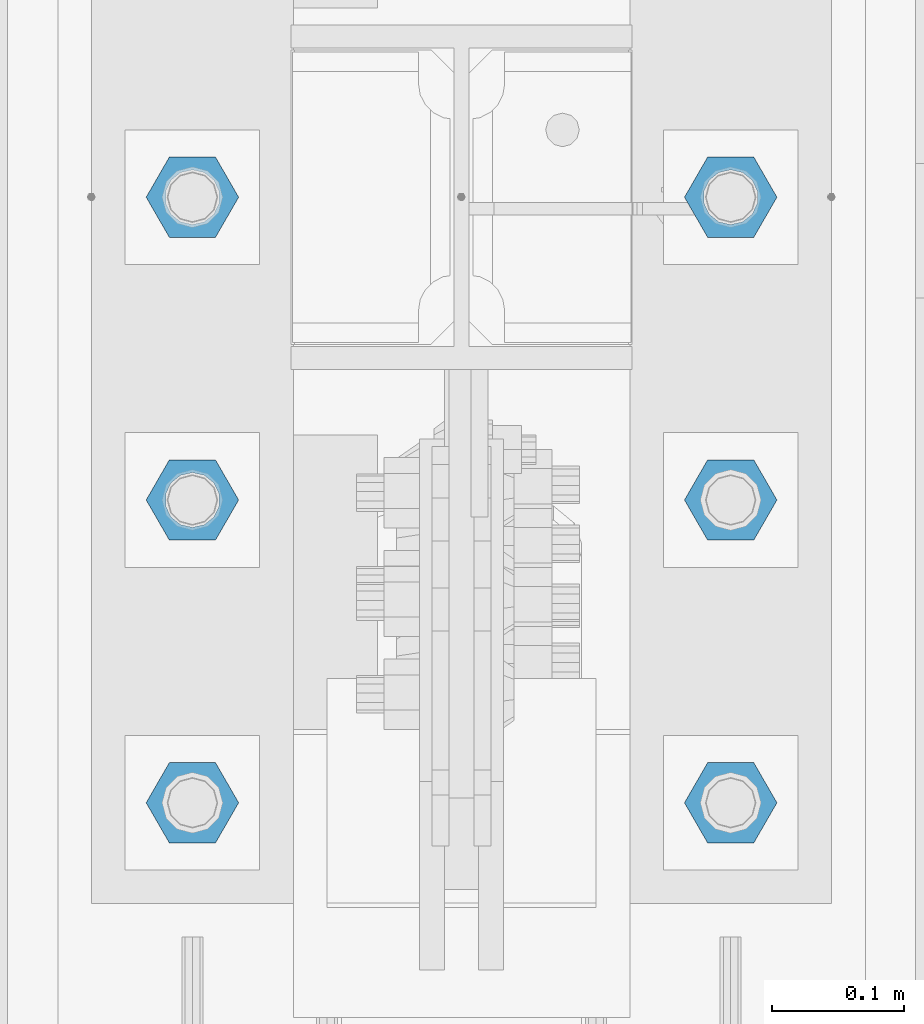
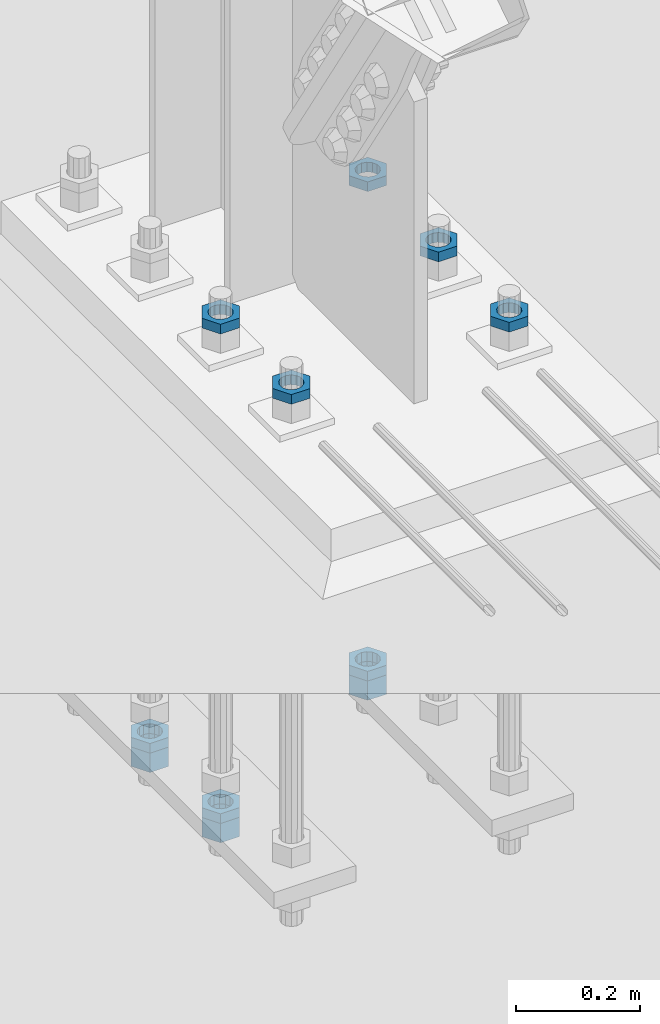
# One storey, part 2857 of 3843: 11 beams, 1 element without a shape of its own.
"""IFC2X3 building model written with IfcOpenShell, lengths in millimetres."""

from ifc_helpers import new_model, si_unit, frame, origin_with_axes, place, context, subcontext, project, spatial, faceted_brep, material, type_object, element, aggregate, save


model = new_model("IFC2X3")

# Units and contexts
model_context = context("Model", 3, precision=1e-05, world=origin_with_axes())
body_context = subcontext(model_context, "Body", "Model", "MODEL_VIEW")
ifc_project = project(units=[si_unit("LENGTHUNIT", "METRE", prefix="MILLI"), si_unit("AREAUNIT", "SQUARE_METRE"), si_unit("VOLUMEUNIT", "CUBIC_METRE"), si_unit("MASSUNIT", "GRAM", prefix="KILO"), si_unit("TIMEUNIT", "SECOND"), si_unit("PLANEANGLEUNIT", "RADIAN"), si_unit("SOLIDANGLEUNIT", "STERADIAN"), si_unit("THERMODYNAMICTEMPERATUREUNIT", "DEGREE_CELSIUS"), si_unit("LUMINOUSINTENSITYUNIT", "LUMEN")], contexts=[model_context])

# Site, building, storey
site_placement = place(None, origin_with_axes())
site = spatial("IfcSite", under=ifc_project, at=site_placement, CompositionType="ELEMENT")
building_placement = place(site_placement, origin_with_axes())
building = spatial("IfcBuilding", under=site, at=building_placement, Name="Undefined", CompositionType="ELEMENT")
storey_placement = place(building_placement, origin_with_axes())
storey = spatial("IfcBuildingStorey", under=building, at=storey_placement, Name="Undefined", CompositionType="ELEMENT", Elevation=0.0)

# Assembly, beams
assembly_placement = place(storey_placement, origin_with_axes())
assembly = element("IfcElementAssembly", 1, at=assembly_placement, inside=storey, Name="TEMPLATE", AssemblyPlace="NOTDEFINED", PredefinedType="RIGID_FRAME")
ifc_material = material(Name="STEEL/A572-50")
beam_type_1 = type_object("IfcBeamType", Name="1-1/2_HEAVY_HEX_NUT", PredefinedType="NOTDEFINED")
beam_1_placement = place(assembly_placement, frame((-203.2, 104559.100004884, 28905.2), z_axis=(0.0, -1.0, 0.0), x_axis=(0.0, 0.0, -1.0)))
beam_1 = element("IfcBeam", 2, at=beam_1_placement, type_object=beam_type_1, material=ifc_material, Name="NUT", ObjectType="1-1/2_HEAVY_HEX_NUT", context=body_context, shape_type="Brep", body=[
    faceted_brep([(0.0, -34.9199981689453, 0.0), (0.0, -17.4599990844727, -30.25), (38.0999999999985, -17.4599990844727, -30.25), (38.0999999999985, -34.9199981689453, 0.0), (0.0, 17.4599990844727, -30.25), (38.0999999999985, 17.4599990844727, -30.25), (0.0, 34.9199981689453, 0.0), (38.0999999999985, 34.9199981689453, 0.0), (0.0, 17.4599990844727, 30.25), (38.0999999999985, 17.4599990844727, 30.25), (0.0, -17.4599990844727, 30.25), (38.0999999999985, -17.4599990844727, 30.25), (0.0, 0.0, 20.6399993896484), (0.0, 8.9553601105581, 18.5959968835959), (38.0999999999985, 8.9553601105581, 18.5959968835959), (38.0999999999985, 0.0, 20.6399993896484), (0.0, 16.1370013209525, 12.8688291298167), (38.0999999999985, 16.1370013209525, 12.8688291298167), (0.0, 20.1225115123816, 4.59283194104501), (38.0999999999985, 20.1225115123816, 4.59283194104501), (0.0, 20.1225115123816, -4.59283194104501), (38.0999999999985, 20.1225115123816, -4.59283194104501), (0.0, 16.1370013209525, -12.8688291298167), (38.0999999999985, 16.1370013209525, -12.8688291298167), (0.0, 8.9553601105581, -18.5959968835959), (38.0999999999985, 8.9553601105581, -18.5959968835959), (0.0, 0.0, -20.6399993896484), (38.0999999999985, 0.0, -20.6399993896484), (0.0, -8.9553601105581, -18.5959968835959), (38.0999999999985, -8.9553601105581, -18.5959968835959), (0.0, -16.1370013209525, -12.8688291298167), (38.0999999999985, -16.1370013209525, -12.8688291298167), (0.0, -20.1225115123816, -4.59283194104501), (38.0999999999985, -20.1225115123816, -4.59283194104501), (0.0, -20.1225115123816, 4.59283194104501), (38.0999999999985, -20.1225115123816, 4.59283194104501), (0.0, -16.1370013209525, 12.8688291298167), (38.0999999999985, -16.1370013209525, 12.8688291298167), (0.0, -8.9553601105581, 18.5959968835959), (38.0999999999985, -8.9553601105581, 18.5959968835959)], [[[0, 1, 2, 3]], [[1, 4, 5, 2]], [[4, 6, 7, 5]], [[6, 8, 9, 7]], [[8, 10, 11, 9]], [[10, 0, 3, 11]], [[12, 13, 14, 15]], [[13, 16, 17, 14]], [[16, 18, 19, 17]], [[18, 20, 21, 19]], [[20, 22, 23, 21]], [[22, 24, 25, 23]], [[24, 26, 27, 25]], [[26, 28, 29, 27]], [[28, 30, 31, 29]], [[30, 32, 33, 31]], [[32, 34, 35, 33]], [[34, 36, 37, 35]], [[36, 38, 39, 37]], [[38, 12, 15, 39]], [[5, 7, 9, 11, 3, 2], [17, 19, 21, 23, 25, 27, 29, 31, 33, 35, 37, 39, 15, 14]], [[10, 8, 6, 4, 1, 0], [38, 36, 34, 32, 30, 28, 26, 24, 22, 20, 18, 16, 13, 12]]]),
])
beam_2_placement = place(assembly_placement, frame((-203.2, 104330.500004884, 28905.2), z_axis=(0.0, -1.0, 0.0), x_axis=(0.0, 0.0, -1.0)))
beam_2 = element("IfcBeam", 3, at=beam_2_placement, type_object=beam_type_1, material=ifc_material, Name="NUT", ObjectType="1-1/2_HEAVY_HEX_NUT", context=body_context, shape_type="Brep", body=[
    faceted_brep([(0.0, -34.9199981689453, 0.0), (0.0, -17.4599990844727, -30.25), (38.0999999999985, -17.4599990844727, -30.25), (38.0999999999985, -34.9199981689453, 0.0), (0.0, 17.4599990844727, -30.25), (38.0999999999985, 17.4599990844727, -30.25), (0.0, 34.9199981689453, 0.0), (38.0999999999985, 34.9199981689453, 0.0), (0.0, 17.4599990844727, 30.25), (38.0999999999985, 17.4599990844727, 30.25), (0.0, -17.4599990844727, 30.25), (38.0999999999985, -17.4599990844727, 30.25), (0.0, 0.0, 20.6399993896484), (0.0, 8.9553601105581, 18.5959968835959), (38.0999999999985, 8.9553601105581, 18.5959968835959), (38.0999999999985, 0.0, 20.6399993896484), (0.0, 16.1370013209525, 12.8688291298167), (38.0999999999985, 16.1370013209525, 12.8688291298167), (0.0, 20.1225115123816, 4.59283194104501), (38.0999999999985, 20.1225115123816, 4.59283194104501), (0.0, 20.1225115123816, -4.59283194104501), (38.0999999999985, 20.1225115123816, -4.59283194104501), (0.0, 16.1370013209525, -12.8688291298167), (38.0999999999985, 16.1370013209525, -12.8688291298167), (0.0, 8.9553601105581, -18.5959968835959), (38.0999999999985, 8.9553601105581, -18.5959968835959), (0.0, 0.0, -20.6399993896484), (38.0999999999985, 0.0, -20.6399993896484), (0.0, -8.9553601105581, -18.5959968835959), (38.0999999999985, -8.9553601105581, -18.5959968835959), (0.0, -16.1370013209525, -12.8688291298167), (38.0999999999985, -16.1370013209525, -12.8688291298167), (0.0, -20.1225115123816, -4.59283194104501), (38.0999999999985, -20.1225115123816, -4.59283194104501), (0.0, -20.1225115123816, 4.59283194104501), (38.0999999999985, -20.1225115123816, 4.59283194104501), (0.0, -16.1370013209525, 12.8688291298167), (38.0999999999985, -16.1370013209525, 12.8688291298167), (0.0, -8.9553601105581, 18.5959968835959), (38.0999999999985, -8.9553601105581, 18.5959968835959)], [[[0, 1, 2, 3]], [[1, 4, 5, 2]], [[4, 6, 7, 5]], [[6, 8, 9, 7]], [[8, 10, 11, 9]], [[10, 0, 3, 11]], [[12, 13, 14, 15]], [[13, 16, 17, 14]], [[16, 18, 19, 17]], [[18, 20, 21, 19]], [[20, 22, 23, 21]], [[22, 24, 25, 23]], [[24, 26, 27, 25]], [[26, 28, 29, 27]], [[28, 30, 31, 29]], [[30, 32, 33, 31]], [[32, 34, 35, 33]], [[34, 36, 37, 35]], [[36, 38, 39, 37]], [[38, 12, 15, 39]], [[5, 7, 9, 11, 3, 2], [17, 19, 21, 23, 25, 27, 29, 31, 33, 35, 37, 39, 15, 14]], [[10, 8, 6, 4, 1, 0], [38, 36, 34, 32, 30, 28, 26, 24, 22, 20, 18, 16, 13, 12]]]),
])
beam_3_placement = place(assembly_placement, frame((203.2, 104559.100019533, 28905.2), z_axis=(0.0, 1.0, 0.0), x_axis=(0.0, 0.0, -1.0)))
beam_3 = element("IfcBeam", 4, at=beam_3_placement, type_object=beam_type_1, material=ifc_material, Name="NUT", ObjectType="1-1/2_HEAVY_HEX_NUT", context=body_context, shape_type="Brep", body=[
    faceted_brep([(0.0, -34.9199981689453, 0.0), (0.0, -17.4599990844727, -30.25), (38.0999999999985, -17.4599990844727, -30.25), (38.0999999999985, -34.9199981689453, 0.0), (0.0, 17.4599990844727, -30.25), (38.0999999999985, 17.4599990844727, -30.25), (0.0, 34.9199981689453, 0.0), (38.0999999999985, 34.9199981689453, 0.0), (0.0, 17.4599990844727, 30.25), (38.0999999999985, 17.4599990844727, 30.25), (0.0, -17.4599990844727, 30.25), (38.0999999999985, -17.4599990844727, 30.25), (0.0, 0.0, 20.6399993896484), (0.0, 8.9553601105581, 18.5959968835959), (38.0999999999985, 8.9553601105581, 18.5959968835959), (38.0999999999985, 0.0, 20.6399993896484), (0.0, 16.1370013209525, 12.8688291298167), (38.0999999999985, 16.1370013209525, 12.8688291298167), (0.0, 20.1225115123816, 4.59283194104501), (38.0999999999985, 20.1225115123816, 4.59283194104501), (0.0, 20.1225115123816, -4.59283194104501), (38.0999999999985, 20.1225115123816, -4.59283194104501), (0.0, 16.1370013209525, -12.8688291298167), (38.0999999999985, 16.1370013209525, -12.8688291298167), (0.0, 8.9553601105581, -18.5959968835959), (38.0999999999985, 8.9553601105581, -18.5959968835959), (0.0, 0.0, -20.6399993896484), (38.0999999999985, 0.0, -20.6399993896484), (0.0, -8.9553601105581, -18.5959968835959), (38.0999999999985, -8.9553601105581, -18.5959968835959), (0.0, -16.1370013209525, -12.8688291298167), (38.0999999999985, -16.1370013209525, -12.8688291298167), (0.0, -20.1225115123816, -4.59283194104501), (38.0999999999985, -20.1225115123816, -4.59283194104501), (0.0, -20.1225115123816, 4.59283194104501), (38.0999999999985, -20.1225115123816, 4.59283194104501), (0.0, -16.1370013209525, 12.8688291298167), (38.0999999999985, -16.1370013209525, 12.8688291298167), (0.0, -8.9553601105581, 18.5959968835959), (38.0999999999985, -8.9553601105581, 18.5959968835959)], [[[0, 1, 2, 3]], [[1, 4, 5, 2]], [[4, 6, 7, 5]], [[6, 8, 9, 7]], [[8, 10, 11, 9]], [[10, 0, 3, 11]], [[12, 13, 14, 15]], [[13, 16, 17, 14]], [[16, 18, 19, 17]], [[18, 20, 21, 19]], [[20, 22, 23, 21]], [[22, 24, 25, 23]], [[24, 26, 27, 25]], [[26, 28, 29, 27]], [[28, 30, 31, 29]], [[30, 32, 33, 31]], [[32, 34, 35, 33]], [[34, 36, 37, 35]], [[36, 38, 39, 37]], [[38, 12, 15, 39]], [[5, 7, 9, 11, 3, 2], [17, 19, 21, 23, 25, 27, 29, 31, 33, 35, 37, 39, 15, 14]], [[10, 8, 6, 4, 1, 0], [38, 36, 34, 32, 30, 28, 26, 24, 22, 20, 18, 16, 13, 12]]]),
])
beam_type_2 = type_object("IfcBeamType", Name="1-1/2_HALF_NUT", PredefinedType="NOTDEFINED")
beam_4_placement = place(assembly_placement, frame((-203.2, 104330.500000001, 29889.45), z_axis=(0.0, -1.0, 0.0), x_axis=(0.0, 0.0, -1.0)))
beam_4 = element("IfcBeam", 5, at=beam_4_placement, type_object=beam_type_2, material=ifc_material, Name="NUT", ObjectType="1-1/2_HALF_NUT", context=body_context, shape_type="Brep", body=[
    faceted_brep([(0.0, -34.9199981689453, 0.0), (0.0, -17.4599990844727, -30.25), (19.0500000000029, -17.4599990844727, -30.25), (19.0500000000029, -34.9199981689453, 0.0), (0.0, 17.4599990844727, -30.25), (19.0500000000029, 17.4599990844727, -30.25), (0.0, 34.9199981689453, 0.0), (19.0500000000029, 34.9199981689453, 0.0), (0.0, 17.4599990844727, 30.25), (19.0500000000029, 17.4599990844727, 30.25), (0.0, -17.4599990844727, 30.25), (19.0500000000029, -17.4599990844727, 30.25), (0.0, 0.0, 20.6399993896484), (0.0, 8.9553601105581, 18.5959968835959), (19.0500000000029, 8.95536011056538, 18.5959968835959), (19.0500000000029, 0.0, 20.6399993896484), (0.0, 16.1370013209525, 12.8688291298167), (19.0500000000029, 16.1370013209489, 12.8688291298167), (0.0, 20.1225115123816, 4.59283194104501), (19.0500000000029, 20.1225115123852, 4.59283194104501), (0.0, 20.1225115123816, -4.59283194104501), (19.0500000000029, 20.1225115123852, -4.59283194104501), (0.0, 16.1370013209525, -12.8688291298167), (19.0500000000029, 16.1370013209489, -12.8688291298167), (0.0, 8.9553601105581, -18.5959968835959), (19.0500000000029, 8.95536011056538, -18.5959968835959), (0.0, 0.0, -20.6399993896484), (19.0500000000029, 0.0, -20.6399993896484), (0.0, -8.9553601105581, -18.5959968835959), (19.0500000000029, -8.95536011056538, -18.5959968835959), (0.0, -16.1370013209525, -12.8688291298167), (19.0500000000029, -16.1370013209489, -12.8688291298167), (0.0, -20.1225115123816, -4.59283194104501), (19.0500000000029, -20.1225115123852, -4.59283194104501), (0.0, -20.1225115123816, 4.59283194104501), (19.0500000000029, -20.1225115123852, 4.59283194104501), (0.0, -16.1370013209525, 12.8688291298167), (19.0500000000029, -16.1370013209489, 12.8688291298167), (0.0, -8.9553601105581, 18.5959968835959), (19.0500000000029, -8.95536011056538, 18.5959968835959)], [[[0, 1, 2, 3]], [[1, 4, 5, 2]], [[4, 6, 7, 5]], [[6, 8, 9, 7]], [[8, 10, 11, 9]], [[10, 0, 3, 11]], [[12, 13, 14, 15]], [[13, 16, 17, 14]], [[16, 18, 19, 17]], [[18, 20, 21, 19]], [[20, 22, 23, 21]], [[22, 24, 25, 23]], [[24, 26, 27, 25]], [[26, 28, 29, 27]], [[28, 30, 31, 29]], [[30, 32, 33, 31]], [[32, 34, 35, 33]], [[34, 36, 37, 35]], [[36, 38, 39, 37]], [[38, 12, 15, 39]], [[5, 7, 9, 11, 3, 2], [17, 19, 21, 23, 25, 27, 29, 31, 33, 35, 37, 39, 15, 14]], [[10, 8, 6, 4, 1, 0], [38, 36, 34, 32, 30, 28, 26, 24, 22, 20, 18, 16, 13, 12]]]),
])
beam_5_placement = place(assembly_placement, frame((203.2, 104559.100024415, 29889.45), z_axis=(0.0, 1.0, 0.0), x_axis=(0.0, 0.0, -1.0)))
beam_5 = element("IfcBeam", 6, at=beam_5_placement, type_object=beam_type_2, material=ifc_material, Name="NUT", ObjectType="1-1/2_HALF_NUT", context=body_context, shape_type="Brep", body=[
    faceted_brep([(0.0, -34.9199981689453, 0.0), (0.0, -17.4599990844727, -30.25), (19.0500000000029, -17.4599990844727, -30.25), (19.0500000000029, -34.9199981689453, 0.0), (0.0, 17.4599990844727, -30.25), (19.0500000000029, 17.4599990844727, -30.25), (0.0, 34.9199981689453, 0.0), (19.0500000000029, 34.9199981689453, 0.0), (0.0, 17.4599990844727, 30.25), (19.0500000000029, 17.4599990844727, 30.25), (0.0, -17.4599990844727, 30.25), (19.0500000000029, -17.4599990844727, 30.25), (0.0, 0.0, 20.6399993896484), (0.0, 8.9553601105581, 18.5959968835959), (19.0500000000029, 8.95536011056538, 18.5959968835959), (19.0500000000029, 0.0, 20.6399993896484), (0.0, 16.1370013209525, 12.8688291298167), (19.0500000000029, 16.1370013209489, 12.8688291298167), (0.0, 20.1225115123816, 4.59283194104501), (19.0500000000029, 20.1225115123852, 4.59283194104501), (0.0, 20.1225115123816, -4.59283194104501), (19.0500000000029, 20.1225115123852, -4.59283194104501), (0.0, 16.1370013209525, -12.8688291298167), (19.0500000000029, 16.1370013209489, -12.8688291298167), (0.0, 8.9553601105581, -18.5959968835959), (19.0500000000029, 8.95536011056538, -18.5959968835959), (0.0, 0.0, -20.6399993896484), (19.0500000000029, 0.0, -20.6399993896484), (0.0, -8.9553601105581, -18.5959968835959), (19.0500000000029, -8.95536011056538, -18.5959968835959), (0.0, -16.1370013209525, -12.8688291298167), (19.0500000000029, -16.1370013209489, -12.8688291298167), (0.0, -20.1225115123816, -4.59283194104501), (19.0500000000029, -20.1225115123852, -4.59283194104501), (0.0, -20.1225115123816, 4.59283194104501), (19.0500000000029, -20.1225115123852, 4.59283194104501), (0.0, -16.1370013209525, 12.8688291298167), (19.0500000000029, -16.1370013209489, 12.8688291298167), (0.0, -8.9553601105581, 18.5959968835959), (19.0500000000029, -8.95536011056538, 18.5959968835959)], [[[0, 1, 2, 3]], [[1, 4, 5, 2]], [[4, 6, 7, 5]], [[6, 8, 9, 7]], [[8, 10, 11, 9]], [[10, 0, 3, 11]], [[12, 13, 14, 15]], [[13, 16, 17, 14]], [[16, 18, 19, 17]], [[18, 20, 21, 19]], [[20, 22, 23, 21]], [[22, 24, 25, 23]], [[24, 26, 27, 25]], [[26, 28, 29, 27]], [[28, 30, 31, 29]], [[30, 32, 33, 31]], [[32, 34, 35, 33]], [[34, 36, 37, 35]], [[36, 38, 39, 37]], [[38, 12, 15, 39]], [[5, 7, 9, 11, 3, 2], [17, 19, 21, 23, 25, 27, 29, 31, 33, 35, 37, 39, 15, 14]], [[10, 8, 6, 4, 1, 0], [38, 36, 34, 32, 30, 28, 26, 24, 22, 20, 18, 16, 13, 12]]]),
])
beam_6_placement = place(assembly_placement, frame((203.2, 104330.500024415, 29889.45), z_axis=(0.0, 1.0, 0.0), x_axis=(0.0, 0.0, -1.0)))
beam_6 = element("IfcBeam", 7, at=beam_6_placement, type_object=beam_type_2, material=ifc_material, Name="NUT", ObjectType="1-1/2_HALF_NUT", context=body_context, shape_type="Brep", body=[
    faceted_brep([(0.0, -34.9199981689453, 0.0), (0.0, -17.4599990844727, -30.25), (19.0500000000029, -17.4599990844727, -30.25), (19.0500000000029, -34.9199981689453, 0.0), (0.0, 17.4599990844727, -30.25), (19.0500000000029, 17.4599990844727, -30.25), (0.0, 34.9199981689453, 0.0), (19.0500000000029, 34.9199981689453, 0.0), (0.0, 17.4599990844727, 30.25), (19.0500000000029, 17.4599990844727, 30.25), (0.0, -17.4599990844727, 30.25), (19.0500000000029, -17.4599990844727, 30.25), (0.0, 0.0, 20.6399993896484), (0.0, 8.9553601105581, 18.5959968835959), (19.0500000000029, 8.95536011056538, 18.5959968835959), (19.0500000000029, 0.0, 20.6399993896484), (0.0, 16.1370013209525, 12.8688291298167), (19.0500000000029, 16.1370013209489, 12.8688291298167), (0.0, 20.1225115123816, 4.59283194104501), (19.0500000000029, 20.1225115123852, 4.59283194104501), (0.0, 20.1225115123816, -4.59283194104501), (19.0500000000029, 20.1225115123852, -4.59283194104501), (0.0, 16.1370013209525, -12.8688291298167), (19.0500000000029, 16.1370013209489, -12.8688291298167), (0.0, 8.9553601105581, -18.5959968835959), (19.0500000000029, 8.95536011056538, -18.5959968835959), (0.0, 0.0, -20.6399993896484), (19.0500000000029, 0.0, -20.6399993896484), (0.0, -8.9553601105581, -18.5959968835959), (19.0500000000029, -8.95536011056538, -18.5959968835959), (0.0, -16.1370013209525, -12.8688291298167), (19.0500000000029, -16.1370013209489, -12.8688291298167), (0.0, -20.1225115123816, -4.59283194104501), (19.0500000000029, -20.1225115123852, -4.59283194104501), (0.0, -20.1225115123816, 4.59283194104501), (19.0500000000029, -20.1225115123852, 4.59283194104501), (0.0, -16.1370013209525, 12.8688291298167), (19.0500000000029, -16.1370013209489, 12.8688291298167), (0.0, -8.9553601105581, 18.5959968835959), (19.0500000000029, -8.95536011056538, 18.5959968835959)], [[[0, 1, 2, 3]], [[1, 4, 5, 2]], [[4, 6, 7, 5]], [[6, 8, 9, 7]], [[8, 10, 11, 9]], [[10, 0, 3, 11]], [[12, 13, 14, 15]], [[13, 16, 17, 14]], [[16, 18, 19, 17]], [[18, 20, 21, 19]], [[20, 22, 23, 21]], [[22, 24, 25, 23]], [[24, 26, 27, 25]], [[26, 28, 29, 27]], [[28, 30, 31, 29]], [[30, 32, 33, 31]], [[32, 34, 35, 33]], [[34, 36, 37, 35]], [[36, 38, 39, 37]], [[38, 12, 15, 39]], [[5, 7, 9, 11, 3, 2], [17, 19, 21, 23, 25, 27, 29, 31, 33, 35, 37, 39, 15, 14]], [[10, 8, 6, 4, 1, 0], [38, 36, 34, 32, 30, 28, 26, 24, 22, 20, 18, 16, 13, 12]]]),
])
beam_7_placement = place(assembly_placement, frame((-203.2, 104101.900024415, 29889.45), z_axis=(0.0, 1.0, 0.0), x_axis=(0.0, 0.0, -1.0)))
beam_7 = element("IfcBeam", 8, at=beam_7_placement, type_object=beam_type_2, material=ifc_material, Name="NUT", ObjectType="1-1/2_HALF_NUT", context=body_context, shape_type="Brep", body=[
    faceted_brep([(0.0, -34.9199981689453, 0.0), (0.0, -17.4599990844727, -30.25), (19.0500000000029, -17.4599990844727, -30.25), (19.0500000000029, -34.9199981689453, 0.0), (0.0, 17.4599990844727, -30.25), (19.0500000000029, 17.4599990844727, -30.25), (0.0, 34.9199981689453, 0.0), (19.0500000000029, 34.9199981689453, 0.0), (0.0, 17.4599990844727, 30.25), (19.0500000000029, 17.4599990844727, 30.25), (0.0, -17.4599990844727, 30.25), (19.0500000000029, -17.4599990844727, 30.25), (0.0, 0.0, 20.6399993896484), (0.0, 8.9553601105581, 18.5959968835959), (19.0500000000029, 8.95536011056538, 18.5959968835959), (19.0500000000029, 0.0, 20.6399993896484), (0.0, 16.1370013209525, 12.8688291298167), (19.0500000000029, 16.1370013209489, 12.8688291298167), (0.0, 20.1225115123816, 4.59283194104501), (19.0500000000029, 20.1225115123852, 4.59283194104501), (0.0, 20.1225115123816, -4.59283194104501), (19.0500000000029, 20.1225115123852, -4.59283194104501), (0.0, 16.1370013209525, -12.8688291298167), (19.0500000000029, 16.1370013209489, -12.8688291298167), (0.0, 8.9553601105581, -18.5959968835959), (19.0500000000029, 8.95536011056538, -18.5959968835959), (0.0, 0.0, -20.6399993896484), (19.0500000000029, 0.0, -20.6399993896484), (0.0, -8.9553601105581, -18.5959968835959), (19.0500000000029, -8.95536011056538, -18.5959968835959), (0.0, -16.1370013209525, -12.8688291298167), (19.0500000000029, -16.1370013209489, -12.8688291298167), (0.0, -20.1225115123816, -4.59283194104501), (19.0500000000029, -20.1225115123852, -4.59283194104501), (0.0, -20.1225115123816, 4.59283194104501), (19.0500000000029, -20.1225115123852, 4.59283194104501), (0.0, -16.1370013209525, 12.8688291298167), (19.0500000000029, -16.1370013209489, 12.8688291298167), (0.0, -8.9553601105581, 18.5959968835959), (19.0500000000029, -8.95536011056538, 18.5959968835959)], [[[0, 1, 2, 3]], [[1, 4, 5, 2]], [[4, 6, 7, 5]], [[6, 8, 9, 7]], [[8, 10, 11, 9]], [[10, 0, 3, 11]], [[12, 13, 14, 15]], [[13, 16, 17, 14]], [[16, 18, 19, 17]], [[18, 20, 21, 19]], [[20, 22, 23, 21]], [[22, 24, 25, 23]], [[24, 26, 27, 25]], [[26, 28, 29, 27]], [[28, 30, 31, 29]], [[30, 32, 33, 31]], [[32, 34, 35, 33]], [[34, 36, 37, 35]], [[36, 38, 39, 37]], [[38, 12, 15, 39]], [[5, 7, 9, 11, 3, 2], [17, 19, 21, 23, 25, 27, 29, 31, 33, 35, 37, 39, 15, 14]], [[10, 8, 6, 4, 1, 0], [38, 36, 34, 32, 30, 28, 26, 24, 22, 20, 18, 16, 13, 12]]]),
])
beam_8_placement = place(assembly_placement, frame((203.2, 104101.900024415, 29889.45), z_axis=(0.0, 1.0, 0.0), x_axis=(0.0, 0.0, -1.0)))
beam_8 = element("IfcBeam", 9, at=beam_8_placement, type_object=beam_type_2, material=ifc_material, Name="NUT", ObjectType="1-1/2_HALF_NUT", context=body_context, shape_type="Brep", body=[
    faceted_brep([(0.0, -34.9199981689453, 0.0), (0.0, -17.4599990844727, -30.25), (19.0500000000029, -17.4599990844727, -30.25), (19.0500000000029, -34.9199981689453, 0.0), (0.0, 17.4599990844727, -30.25), (19.0500000000029, 17.4599990844727, -30.25), (0.0, 34.9199981689453, 0.0), (19.0500000000029, 34.9199981689453, 0.0), (0.0, 17.4599990844727, 30.25), (19.0500000000029, 17.4599990844727, 30.25), (0.0, -17.4599990844727, 30.25), (19.0500000000029, -17.4599990844727, 30.25), (0.0, 0.0, 20.6399993896484), (0.0, 8.9553601105581, 18.5959968835959), (19.0500000000029, 8.95536011056538, 18.5959968835959), (19.0500000000029, 0.0, 20.6399993896484), (0.0, 16.1370013209525, 12.8688291298167), (19.0500000000029, 16.1370013209489, 12.8688291298167), (0.0, 20.1225115123816, 4.59283194104501), (19.0500000000029, 20.1225115123852, 4.59283194104501), (0.0, 20.1225115123816, -4.59283194104501), (19.0500000000029, 20.1225115123852, -4.59283194104501), (0.0, 16.1370013209525, -12.8688291298167), (19.0500000000029, 16.1370013209489, -12.8688291298167), (0.0, 8.9553601105581, -18.5959968835959), (19.0500000000029, 8.95536011056538, -18.5959968835959), (0.0, 0.0, -20.6399993896484), (19.0500000000029, 0.0, -20.6399993896484), (0.0, -8.9553601105581, -18.5959968835959), (19.0500000000029, -8.95536011056538, -18.5959968835959), (0.0, -16.1370013209525, -12.8688291298167), (19.0500000000029, -16.1370013209489, -12.8688291298167), (0.0, -20.1225115123816, -4.59283194104501), (19.0500000000029, -20.1225115123852, -4.59283194104501), (0.0, -20.1225115123816, 4.59283194104501), (19.0500000000029, -20.1225115123852, 4.59283194104501), (0.0, -16.1370013209525, 12.8688291298167), (19.0500000000029, -16.1370013209489, 12.8688291298167), (0.0, -8.9553601105581, 18.5959968835959), (19.0500000000029, -8.95536011056538, 18.5959968835959)], [[[0, 1, 2, 3]], [[1, 4, 5, 2]], [[4, 6, 7, 5]], [[6, 8, 9, 7]], [[8, 10, 11, 9]], [[10, 0, 3, 11]], [[12, 13, 14, 15]], [[13, 16, 17, 14]], [[16, 18, 19, 17]], [[18, 20, 21, 19]], [[20, 22, 23, 21]], [[22, 24, 25, 23]], [[24, 26, 27, 25]], [[26, 28, 29, 27]], [[28, 30, 31, 29]], [[30, 32, 33, 31]], [[32, 34, 35, 33]], [[34, 36, 37, 35]], [[36, 38, 39, 37]], [[38, 12, 15, 39]], [[5, 7, 9, 11, 3, 2], [17, 19, 21, 23, 25, 27, 29, 31, 33, 35, 37, 39, 15, 14]], [[10, 8, 6, 4, 1, 0], [38, 36, 34, 32, 30, 28, 26, 24, 22, 20, 18, 16, 13, 12]]]),
])
beam_9_placement = place(assembly_placement, frame((-203.2, 104559.100012208, 28924.25), z_axis=(0.0, -1.0, 0.0), x_axis=(0.0, 0.0, -1.0)))
beam_9 = element("IfcBeam", 10, at=beam_9_placement, type_object=beam_type_2, material=ifc_material, Name="NUT", ObjectType="1-1/2_HALF_NUT", context=body_context, shape_type="Brep", body=[
    faceted_brep([(0.0, -34.9199981689453, 0.0), (0.0, -17.4599990844727, -30.25), (19.0500000000029, -17.4599990844727, -30.25), (19.0500000000029, -34.9199981689453, 0.0), (0.0, 17.4599990844727, -30.25), (19.0500000000029, 17.4599990844727, -30.25), (0.0, 34.9199981689453, 0.0), (19.0500000000029, 34.9199981689453, 0.0), (0.0, 17.4599990844727, 30.25), (19.0500000000029, 17.4599990844727, 30.25), (0.0, -17.4599990844727, 30.25), (19.0500000000029, -17.4599990844727, 30.25), (0.0, 0.0, 20.6399993896484), (0.0, 8.9553601105581, 18.5959968835959), (19.0500000000029, 8.95536011056538, 18.5959968835959), (19.0500000000029, 0.0, 20.6399993896484), (0.0, 16.1370013209525, 12.8688291298167), (19.0500000000029, 16.1370013209489, 12.8688291298167), (0.0, 20.1225115123816, 4.59283194104501), (19.0500000000029, 20.1225115123852, 4.59283194104501), (0.0, 20.1225115123816, -4.59283194104501), (19.0500000000029, 20.1225115123852, -4.59283194104501), (0.0, 16.1370013209525, -12.8688291298167), (19.0500000000029, 16.1370013209489, -12.8688291298167), (0.0, 8.9553601105581, -18.5959968835959), (19.0500000000029, 8.95536011056538, -18.5959968835959), (0.0, 0.0, -20.6399993896484), (19.0500000000029, 0.0, -20.6399993896484), (0.0, -8.9553601105581, -18.5959968835959), (19.0500000000029, -8.95536011056538, -18.5959968835959), (0.0, -16.1370013209525, -12.8688291298167), (19.0500000000029, -16.1370013209489, -12.8688291298167), (0.0, -20.1225115123816, -4.59283194104501), (19.0500000000029, -20.1225115123852, -4.59283194104501), (0.0, -20.1225115123816, 4.59283194104501), (19.0500000000029, -20.1225115123852, 4.59283194104501), (0.0, -16.1370013209525, 12.8688291298167), (19.0500000000029, -16.1370013209489, 12.8688291298167), (0.0, -8.9553601105581, 18.5959968835959), (19.0500000000029, -8.95536011056538, 18.5959968835959)], [[[0, 1, 2, 3]], [[1, 4, 5, 2]], [[4, 6, 7, 5]], [[6, 8, 9, 7]], [[8, 10, 11, 9]], [[10, 0, 3, 11]], [[12, 13, 14, 15]], [[13, 16, 17, 14]], [[16, 18, 19, 17]], [[18, 20, 21, 19]], [[20, 22, 23, 21]], [[22, 24, 25, 23]], [[24, 26, 27, 25]], [[26, 28, 29, 27]], [[28, 30, 31, 29]], [[30, 32, 33, 31]], [[32, 34, 35, 33]], [[34, 36, 37, 35]], [[36, 38, 39, 37]], [[38, 12, 15, 39]], [[5, 7, 9, 11, 3, 2], [17, 19, 21, 23, 25, 27, 29, 31, 33, 35, 37, 39, 15, 14]], [[10, 8, 6, 4, 1, 0], [38, 36, 34, 32, 30, 28, 26, 24, 22, 20, 18, 16, 13, 12]]]),
])
beam_10_placement = place(assembly_placement, frame((-203.2, 104330.500012208, 28924.25), z_axis=(0.0, -1.0, 0.0), x_axis=(0.0, 0.0, -1.0)))
beam_10 = element("IfcBeam", 11, at=beam_10_placement, type_object=beam_type_2, material=ifc_material, Name="NUT", ObjectType="1-1/2_HALF_NUT", context=body_context, shape_type="Brep", body=[
    faceted_brep([(0.0, -34.9199981689453, 0.0), (0.0, -17.4599990844727, -30.25), (19.0500000000029, -17.4599990844727, -30.25), (19.0500000000029, -34.9199981689453, 0.0), (0.0, 17.4599990844727, -30.25), (19.0500000000029, 17.4599990844727, -30.25), (0.0, 34.9199981689453, 0.0), (19.0500000000029, 34.9199981689453, 0.0), (0.0, 17.4599990844727, 30.25), (19.0500000000029, 17.4599990844727, 30.25), (0.0, -17.4599990844727, 30.25), (19.0500000000029, -17.4599990844727, 30.25), (0.0, 0.0, 20.6399993896484), (0.0, 8.9553601105581, 18.5959968835959), (19.0500000000029, 8.95536011056538, 18.5959968835959), (19.0500000000029, 0.0, 20.6399993896484), (0.0, 16.1370013209525, 12.8688291298167), (19.0500000000029, 16.1370013209489, 12.8688291298167), (0.0, 20.1225115123816, 4.59283194104501), (19.0500000000029, 20.1225115123852, 4.59283194104501), (0.0, 20.1225115123816, -4.59283194104501), (19.0500000000029, 20.1225115123852, -4.59283194104501), (0.0, 16.1370013209525, -12.8688291298167), (19.0500000000029, 16.1370013209489, -12.8688291298167), (0.0, 8.9553601105581, -18.5959968835959), (19.0500000000029, 8.95536011056538, -18.5959968835959), (0.0, 0.0, -20.6399993896484), (19.0500000000029, 0.0, -20.6399993896484), (0.0, -8.9553601105581, -18.5959968835959), (19.0500000000029, -8.95536011056538, -18.5959968835959), (0.0, -16.1370013209525, -12.8688291298167), (19.0500000000029, -16.1370013209489, -12.8688291298167), (0.0, -20.1225115123816, -4.59283194104501), (19.0500000000029, -20.1225115123852, -4.59283194104501), (0.0, -20.1225115123816, 4.59283194104501), (19.0500000000029, -20.1225115123852, 4.59283194104501), (0.0, -16.1370013209525, 12.8688291298167), (19.0500000000029, -16.1370013209489, 12.8688291298167), (0.0, -8.9553601105581, 18.5959968835959), (19.0500000000029, -8.95536011056538, 18.5959968835959)], [[[0, 1, 2, 3]], [[1, 4, 5, 2]], [[4, 6, 7, 5]], [[6, 8, 9, 7]], [[8, 10, 11, 9]], [[10, 0, 3, 11]], [[12, 13, 14, 15]], [[13, 16, 17, 14]], [[16, 18, 19, 17]], [[18, 20, 21, 19]], [[20, 22, 23, 21]], [[22, 24, 25, 23]], [[24, 26, 27, 25]], [[26, 28, 29, 27]], [[28, 30, 31, 29]], [[30, 32, 33, 31]], [[32, 34, 35, 33]], [[34, 36, 37, 35]], [[36, 38, 39, 37]], [[38, 12, 15, 39]], [[5, 7, 9, 11, 3, 2], [17, 19, 21, 23, 25, 27, 29, 31, 33, 35, 37, 39, 15, 14]], [[10, 8, 6, 4, 1, 0], [38, 36, 34, 32, 30, 28, 26, 24, 22, 20, 18, 16, 13, 12]]]),
])
beam_11_placement = place(assembly_placement, frame((203.2, 104559.100012208, 28924.25), z_axis=(0.0, 1.0, 0.0), x_axis=(0.0, 0.0, -1.0)))
beam_11 = element("IfcBeam", 12, at=beam_11_placement, type_object=beam_type_2, material=ifc_material, Name="NUT", ObjectType="1-1/2_HALF_NUT", context=body_context, shape_type="Brep", body=[
    faceted_brep([(0.0, -34.9199981689453, 0.0), (0.0, -17.4599990844727, -30.25), (19.0500000000029, -17.4599990844727, -30.25), (19.0500000000029, -34.9199981689453, 0.0), (0.0, 17.4599990844727, -30.25), (19.0500000000029, 17.4599990844727, -30.25), (0.0, 34.9199981689453, 0.0), (19.0500000000029, 34.9199981689453, 0.0), (0.0, 17.4599990844727, 30.25), (19.0500000000029, 17.4599990844727, 30.25), (0.0, -17.4599990844727, 30.25), (19.0500000000029, -17.4599990844727, 30.25), (0.0, 0.0, 20.6399993896484), (0.0, 8.9553601105581, 18.5959968835959), (19.0500000000029, 8.95536011056538, 18.5959968835959), (19.0500000000029, 0.0, 20.6399993896484), (0.0, 16.1370013209525, 12.8688291298167), (19.0500000000029, 16.1370013209489, 12.8688291298167), (0.0, 20.1225115123816, 4.59283194104501), (19.0500000000029, 20.1225115123852, 4.59283194104501), (0.0, 20.1225115123816, -4.59283194104501), (19.0500000000029, 20.1225115123852, -4.59283194104501), (0.0, 16.1370013209525, -12.8688291298167), (19.0500000000029, 16.1370013209489, -12.8688291298167), (0.0, 8.9553601105581, -18.5959968835959), (19.0500000000029, 8.95536011056538, -18.5959968835959), (0.0, 0.0, -20.6399993896484), (19.0500000000029, 0.0, -20.6399993896484), (0.0, -8.9553601105581, -18.5959968835959), (19.0500000000029, -8.95536011056538, -18.5959968835959), (0.0, -16.1370013209525, -12.8688291298167), (19.0500000000029, -16.1370013209489, -12.8688291298167), (0.0, -20.1225115123816, -4.59283194104501), (19.0500000000029, -20.1225115123852, -4.59283194104501), (0.0, -20.1225115123816, 4.59283194104501), (19.0500000000029, -20.1225115123852, 4.59283194104501), (0.0, -16.1370013209525, 12.8688291298167), (19.0500000000029, -16.1370013209489, 12.8688291298167), (0.0, -8.9553601105581, 18.5959968835959), (19.0500000000029, -8.95536011056538, 18.5959968835959)], [[[0, 1, 2, 3]], [[1, 4, 5, 2]], [[4, 6, 7, 5]], [[6, 8, 9, 7]], [[8, 10, 11, 9]], [[10, 0, 3, 11]], [[12, 13, 14, 15]], [[13, 16, 17, 14]], [[16, 18, 19, 17]], [[18, 20, 21, 19]], [[20, 22, 23, 21]], [[22, 24, 25, 23]], [[24, 26, 27, 25]], [[26, 28, 29, 27]], [[28, 30, 31, 29]], [[30, 32, 33, 31]], [[32, 34, 35, 33]], [[34, 36, 37, 35]], [[36, 38, 39, 37]], [[38, 12, 15, 39]], [[5, 7, 9, 11, 3, 2], [17, 19, 21, 23, 25, 27, 29, 31, 33, 35, 37, 39, 15, 14]], [[10, 8, 6, 4, 1, 0], [38, 36, 34, 32, 30, 28, 26, 24, 22, 20, 18, 16, 13, 12]]]),
])
aggregate(assembly, [beam_4, beam_5, beam_6, beam_7, beam_8, beam_9, beam_1, beam_10, beam_2, beam_11, beam_3])

save(model, "model.ifc")
